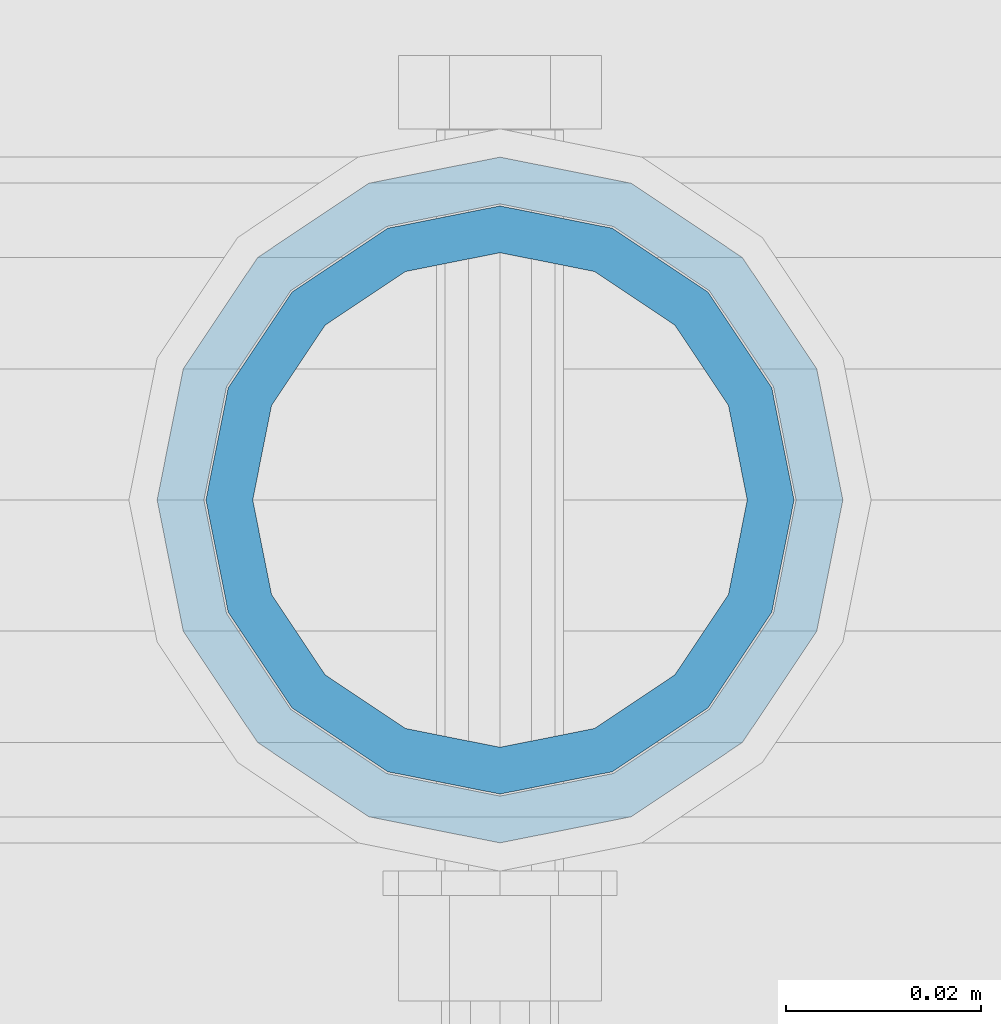
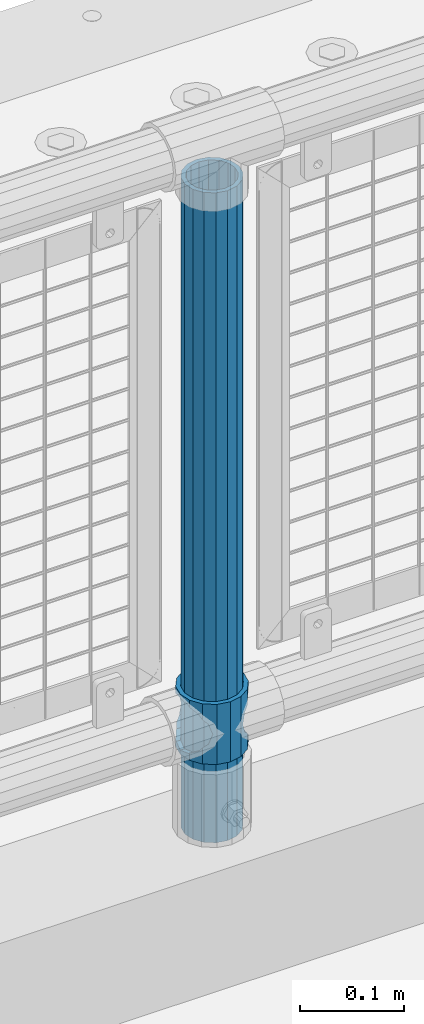
# One storey, part 64 of 242: 2 columns.
"""IFC2X3 building model written with IfcOpenShell, lengths in millimetres."""

from ifc_helpers import new_model, si_unit, frame, origin_with_axes, place, context, subcontext, project, spatial, faceted_brep, material, type_object, element, save


model = new_model("IFC2X3")

# Units and contexts
model_context = context("Model", 3, precision=1e-05, world=origin_with_axes())
body_context = subcontext(model_context, "Body", "Model", "MODEL_VIEW")
ifc_project = project(units=[si_unit("LENGTHUNIT", "METRE", prefix="MILLI"), si_unit("AREAUNIT", "SQUARE_METRE"), si_unit("VOLUMEUNIT", "CUBIC_METRE"), si_unit("MASSUNIT", "GRAM", prefix="KILO"), si_unit("TIMEUNIT", "SECOND"), si_unit("PLANEANGLEUNIT", "RADIAN"), si_unit("SOLIDANGLEUNIT", "STERADIAN"), si_unit("THERMODYNAMICTEMPERATUREUNIT", "DEGREE_CELSIUS"), si_unit("LUMINOUSINTENSITYUNIT", "LUMEN")], contexts=[model_context])

# Site, building, storey
site_placement = place(None, origin_with_axes())
site = spatial("IfcSite", under=ifc_project, at=site_placement, CompositionType="ELEMENT")
building_placement = place(site_placement, origin_with_axes())
building = spatial("IfcBuilding", under=site, at=building_placement, Name="Standard", CompositionType="ELEMENT")
storey_placement = place(building_placement, origin_with_axes())
storey = spatial("IfcBuildingStorey", under=building, at=storey_placement, Name="Undefined", CompositionType="ELEMENT", Elevation=0.0)

# Columns
ifc_material_1 = material()
column_type_1 = type_object("IfcColumnType", PredefinedType="NOTDEFINED")
column_1_placement = place(storey_placement, frame((-40196.0, -19335.5, 168.02), z_axis=(-1.0, 0.0, 0.0), x_axis=(0.0, 0.0, 1.0)))
element("IfcColumn", 1, at=column_1_placement, inside=storey, type_object=column_type_1, material=ifc_material_1, context=body_context, shape_type="Brep", body=[
    faceted_brep([(0.0, -25.3499999999985, 0.0), (0.0, -23.4203461491597, 9.70102501045403), (760.0, -23.4203461491597, 9.70102501045403), (760.0, -25.3499999999985, 0.0), (0.0, -17.9251569030785, 17.9251569030785), (760.0, -17.9251569030785, 17.9251569030785), (0.0, -9.70102501045403, 23.4203461491597), (760.0, -9.70102501045403, 23.4203461491597), (0.0, 0.0, 25.3499999999985), (760.0, 0.0, 25.3499999999985), (0.0, 9.70102501045403, 23.4203461491597), (760.0, 9.70102501045403, 23.4203461491597), (0.0, 17.9251569030785, 17.9251569030785), (760.0, 17.9251569030785, 17.9251569030785), (0.0, 23.4203461491597, 9.70102501045403), (760.0, 23.4203461491597, 9.70102501045403), (0.0, 25.3499999999985, 0.0), (760.0, 25.3499999999985, 0.0), (0.0, 23.4203461491597, -9.70102501045403), (760.0, 23.4203461491597, -9.70102501045403), (0.0, 17.9251569030785, -17.9251569030785), (760.0, 17.9251569030785, -17.9251569030785), (0.0, 9.70102501045403, -23.4203461491597), (760.0, 9.70102501045403, -23.4203461491597), (0.0, 0.0, -25.3499999999985), (760.0, 0.0, -25.3499999999985), (0.0, -9.70102501045403, -23.4203461491597), (760.0, -9.70102501045403, -23.4203461491597), (0.0, -17.9251569030785, -17.9251569030785), (760.0, -17.9251569030785, -17.9251569030785), (0.0, -23.4203461491597, -9.70102501045403), (760.0, -23.4203461491597, -9.70102501045403), (0.0, -30.1500000000015, 0.0), (0.0, -27.8549679052157, -11.5379054858058), (760.0, -27.8549679052157, -11.5379054858058), (760.0, -30.1500000000015, 0.0), (0.0, -21.3192694527752, -21.3192694527752), (760.0, -21.3192694527752, -21.3192694527752), (0.0, -11.5379054858058, -27.8549679052157), (760.0, -11.5379054858058, -27.8549679052157), (0.0, 0.0, -30.1500000000015), (760.0, 0.0, -30.1500000000015), (0.0, 11.5379054858058, -27.8549679052157), (760.0, 11.5379054858058, -27.8549679052157), (0.0, 21.3192694527752, -21.3192694527752), (760.0, 21.3192694527752, -21.3192694527752), (0.0, 27.8549679052157, -11.5379054858058), (760.0, 27.8549679052157, -11.5379054858058), (0.0, 30.1500000000015, 0.0), (760.0, 30.1500000000015, 0.0), (0.0, 27.8549679052157, 11.5379054858058), (760.0, 27.8549679052157, 11.5379054858058), (0.0, 21.3192694527752, 21.3192694527752), (760.0, 21.3192694527752, 21.3192694527752), (0.0, 11.5379054858058, 27.8549679052157), (760.0, 11.5379054858058, 27.8549679052157), (0.0, 0.0, 30.1500000000015), (760.0, 0.0, 30.1500000000015), (0.0, -11.5379054858058, 27.8549679052157), (760.0, -11.5379054858058, 27.8549679052157), (0.0, -21.3192694527752, 21.3192694527752), (760.0, -21.3192694527752, 21.3192694527752), (0.0, -27.8549679052157, 11.5379054858058), (760.0, -27.8549679052157, 11.5379054858058)], [[[0, 1, 2, 3]], [[1, 4, 5, 2]], [[4, 6, 7, 5]], [[6, 8, 9, 7]], [[8, 10, 11, 9]], [[10, 12, 13, 11]], [[12, 14, 15, 13]], [[14, 16, 17, 15]], [[16, 18, 19, 17]], [[18, 20, 21, 19]], [[20, 22, 23, 21]], [[22, 24, 25, 23]], [[24, 26, 27, 25]], [[26, 28, 29, 27]], [[28, 30, 31, 29]], [[30, 0, 3, 31]], [[32, 33, 34, 35]], [[33, 36, 37, 34]], [[36, 38, 39, 37]], [[38, 40, 41, 39]], [[40, 42, 43, 41]], [[42, 44, 45, 43]], [[44, 46, 47, 45]], [[46, 48, 49, 47]], [[48, 50, 51, 49]], [[50, 52, 53, 51]], [[52, 54, 55, 53]], [[54, 56, 57, 55]], [[56, 58, 59, 57]], [[58, 60, 61, 59]], [[60, 62, 63, 61]], [[62, 32, 35, 63]], [[37, 39, 41, 43, 45, 47, 49, 51, 53, 55, 57, 59, 61, 63, 35, 34], [5, 7, 9, 11, 13, 15, 17, 19, 21, 23, 25, 27, 29, 31, 3, 2]], [[62, 60, 58, 56, 54, 52, 50, 48, 46, 44, 42, 40, 38, 36, 33, 32], [30, 28, 26, 24, 22, 20, 18, 16, 14, 12, 10, 8, 6, 4, 1, 0]]]),
])
ifc_material_2 = material(Name="Misc_Undefined")
column_type_2 = type_object("IfcColumnType", PredefinedType="NOTDEFINED")
column_2_placement = place(storey_placement, frame((-40196.0, -19335.5, 263.02), z_axis=(-1.0, 0.0, 0.0), x_axis=(0.0, 0.0, 1.0)))
element("IfcColumn", 2, at=column_2_placement, inside=storey, type_object=column_type_2, material=ifc_material_2, context=body_context, shape_type="Brep", body=[
    faceted_brep([(63.1897438117172, 11.614442172282, -32.8397438117245), (63.1897438117172, 11.614442172282, -28.0397438117143), (56.6106908090114, 21.46069080901, -21.4606908090136), (56.6106908090114, 21.46069080901, -27.1226768591077), (61.9623795176744, 13.4513226476338, -32.4743655677739), (46.7644421722801, 28.0397438117179, -11.6144421722784), (46.7644421722801, 28.0397438117179, -20.0882031229849), (51.5310424080006, 24.8548033587067, -24.8548033587067), (35.1500000000015, 30.35, 0.0), (35.1499999999996, 30.3499999999985, -16.6306603983685), (23.5355578277192, 28.0397438117179, -11.6144421722784), (23.5355578277192, 28.0397438117179, -20.0882031229849), (18.7689575919987, 24.8548033587067, -24.8548033587067), (13.6893091909879, 21.46069080901, -21.4606908090136), (13.6893091909879, 21.46069080901, -27.1226768591077), (8.33762048232262, 13.4513226476338, -32.4743655677739), (7.11025618828211, 11.614442172282, -28.0397438117143), (7.11025618828211, 11.614442172282, -32.8397438117245), (4.79999999999961, 0.0, -30.3499999999985), (4.79999999999961, 0.0, -35.1500000000015), (7.11025618828211, -11.614442172282, -28.0397438117143), (7.11025618828211, -11.614442172282, -32.8397438117172), (13.6893091909879, -21.46069080901, -21.4606908090136), (13.6893091909879, -21.46069080901, -27.1226768591077), (8.33762048232484, -13.4513226476338, -32.4743655677739), (23.5355578277191, -28.0397438117179, -11.6144421722784), (23.5355578277191, -28.0397438117179, -20.0882031229921), (18.7689575919975, -24.8548033587067, -24.8548033587067), (35.1500000000015, -30.35, 0.0), (35.1499999999996, -30.3499999999985, -16.6306603983758), (46.7644421722801, -28.0397438117179, -11.6144421722784), (46.7644421722801, -28.0397438117179, -20.0882031229921), (51.5310424079973, -24.8548033587067, -24.8548033587067), (56.6106908090114, -21.46069080901, -21.4606908090136), (56.6106908090114, -21.46069080901, -27.1226768591077), (61.9623795176767, -13.4513226476338, -32.4743655677739), (63.1897438117172, -11.614442172282, -28.0397438117143), (63.1897438117172, -11.614442172282, -32.8397438117172), (65.4999999999997, 0.0, -30.3499999999985), (65.4999999999997, 0.0, -35.1500000000015), (0.0, -28.0397438117179, -11.6144421722784), (0.0, -30.3499999999985, 0.0), (0.0, -21.46069080901, -21.4606908090136), (0.0, -11.614442172282, -28.0397438117143), (0.0, 0.0, -30.3499999999985), (0.0, 11.614442172282, -28.0397438117143), (0.0, 21.46069080901, -21.4606908090136), (0.0, 28.0397438117179, -11.6144421722784), (0.0, 30.3499999999985, 0.0), (0.0, 28.0397438117179, 11.6144421722784), (23.5355578277192, 28.0397438117179, 11.614442172282), (0.0, 21.46069080901, 21.4606908090136), (13.6893091909879, 21.46069080901, 21.46069080901), (0.0, 11.614442172282, 28.0397438117143), (7.11025618828211, 11.614442172282, 28.0397438117179), (0.0, 0.0, 30.3499999999985), (4.79999999999961, 0.0, 30.3499999999985), (0.0, -11.614442172282, 28.0397438117143), (7.11025618828205, -11.614442172282, 28.0397438117179), (0.0, -21.46069080901, 21.4606908090136), (13.6893091909879, -21.46069080901, 21.46069080901), (0.0, -28.0397438117179, 11.6144421722784), (23.5355578277191, -28.0397438117179, 11.614442172282), (0.0, -32.4743655677703, 13.4513226476338), (0.0, -35.1500000000015, 0.0), (70.2999999999993, -35.1500000000015, 0.0), (70.2999999999993, -32.4743655677703, 13.4513226476338), (0.0, 13.4513226476338, -32.4743655677739), (0.0, 24.8548033587067, -24.8548033587067), (0.0, 0.0, -35.1500000000015), (0.0, -13.4513226476338, -32.4743655677739), (0.0, -24.8548033587067, -24.8548033587067), (0.0, -24.8548033587067, 24.8548033587067), (0.0, -13.4513226476338, 32.4743655677739), (0.0, 0.0, 35.1500000000015), (0.0, 13.4513226476338, 32.4743655677739), (0.0, 24.8548033587067, 24.8548033587067), (0.0, 32.4743655677703, 13.4513226476338), (0.0, 35.1500000000015, 0.0), (0.0, 32.4743655677703, -13.4513226476338), (0.0, -32.4743655677703, -13.4513226476338), (70.2999999999993, 32.4743655677703, 13.4513226476338), (70.2999999999993, 35.1500000000015, 0.0), (70.2999999999993, 32.4743655677703, -13.4513226476338), (70.2999999999993, 24.8548033587067, -24.8548033587067), (70.2999999999993, 13.4513226476338, -32.4743655677739), (70.2999999999993, 0.0, -35.1500000000015), (70.2999999999993, -13.4513226476338, -32.4743655677739), (70.2999999999993, -24.8548033587067, -24.8548033587067), (70.2999999999993, -32.4743655677703, -13.4513226476338), (70.2999999999993, 28.0397438117179, 11.6144421722784), (70.2999999999993, 21.46069080901, 21.4606908090136), (56.6106908090114, 21.46069080901, 21.46069080901), (46.7644421722801, 28.0397438117179, 11.614442172282), (70.2999999999993, 11.614442172282, 28.0397438117143), (63.1897438117172, 11.614442172282, 28.0397438117179), (70.2999999999993, 0.0, 30.3499999999985), (65.4999999999997, 0.0, 30.3499999999985), (70.2999999999993, -11.614442172282, 28.0397438117143), (63.1897438117172, -11.614442172282, 28.0397438117179), (70.2999999999993, -21.46069080901, 21.4606908090136), (56.6106908090114, -21.46069080901, 21.46069080901), (70.2999999999993, -28.0397438117179, 11.6144421722784), (46.7644421722801, -28.0397438117179, 11.614442172282), (70.2999999999993, -11.614442172282, -28.0397438117143), (70.2999999999993, 0.0, -30.3499999999985), (70.2999999999993, -21.46069080901, -21.4606908090136), (70.2999999999993, -28.0397438117179, -11.6144421722784), (70.2999999999993, -30.3499999999985, 0.0), (70.2999999999993, 24.8548033587067, 24.8548033587067), (70.2999999999993, 13.4513226476338, 32.4743655677739), (70.2999999999993, 0.0, 35.1500000000015), (70.2999999999993, -13.4513226476338, 32.4743655677739), (70.2999999999993, -24.8548033587067, 24.8548033587067), (70.2999999999993, 30.3499999999985, 0.0), (70.2999999999993, 28.0397438117179, -11.6144421722784), (70.2999999999993, 21.46069080901, -21.4606908090136), (70.2999999999993, 11.614442172282, -28.0397438117143), (61.9623795176744, 13.4513226476338, 32.4743655677703), (51.5310424080006, 24.8548033587067, 24.8548033587067), (56.6106908090114, 21.46069080901, 27.1226768591077), (65.4999999999997, 0.0, 35.1500000000015), (63.1897438117172, 11.614442172282, 32.8397438117136), (63.1897438117172, -11.614442172282, 32.8397438117172), (61.9623795176767, -13.4513226476338, 32.4743655677703), (56.6106908090114, -21.46069080901, 27.1226768591077), (51.5310424080038, -24.8548033587067, 24.8548033587067), (18.7689575919954, -24.8548033587067, 24.8548033587067), (46.7644421722801, -28.0397438117179, 20.0882031229885), (35.1499999999996, -30.3499999999985, 16.6306603983685), (23.5355578277191, -28.0397438117179, 20.0882031229885), (8.33762048232484, -13.4513226476338, 32.4743655677703), (13.6893091909879, -21.46069080901, 27.1226768591077), (4.79999999999961, 0.0, 35.1500000000015), (7.11025618828205, -11.614442172282, 32.8397438117172), (7.11025618828211, 11.614442172282, 32.8397438117136), (8.33762048232262, 13.4513226476338, 32.4743655677703), (13.6893091909879, 21.46069080901, 27.1226768591077), (18.768957592002, 24.8548033587067, 24.8548033587067), (23.5355578277192, 28.0397438117179, 20.0882031229812), (35.1499999999996, 30.3499999999985, 16.6306603983721), (46.7644421722801, 28.0397438117179, 20.0882031229812)], [[[0, 1, 2, 3, 4]], [[3, 2, 5, 6, 7]], [[6, 5, 8, 9]], [[9, 8, 10, 11]], [[12, 11, 10, 13, 14]], [[15, 14, 13, 16, 17]], [[17, 16, 18, 19]], [[19, 18, 20, 21]], [[21, 20, 22, 23, 24]], [[23, 22, 25, 26, 27]], [[26, 25, 28, 29]], [[29, 28, 30, 31]], [[32, 31, 30, 33, 34]], [[35, 34, 33, 36, 37]], [[37, 36, 38, 39]], [[39, 38, 1, 0]], [[40, 41, 28, 25]], [[42, 40, 25, 22]], [[43, 42, 22, 20]], [[44, 43, 20, 18]], [[45, 44, 18, 16]], [[46, 45, 16, 13]], [[47, 46, 13, 10]], [[48, 47, 10, 8]], [[49, 48, 8, 50]], [[51, 49, 50, 52]], [[53, 51, 52, 54]], [[55, 53, 54, 56]], [[57, 55, 56, 58]], [[59, 57, 58, 60]], [[61, 59, 60, 62]], [[41, 61, 62, 28]], [[63, 64, 65, 66]], [[67, 68, 12, 14, 15]], [[69, 67, 15, 17, 19]], [[24, 70, 69, 19, 21]], [[27, 71, 70, 24, 23]], [[63, 72, 73, 74, 75, 76, 77, 78, 79, 68, 67, 69, 70, 71, 80, 64], [40, 42, 43, 44, 45, 46, 47, 48, 49, 51, 53, 55, 57, 59, 61, 41]], [[78, 77, 81, 82]], [[79, 78, 82, 83]], [[68, 79, 83, 84, 7, 6, 9, 11, 12]], [[7, 84, 85, 4, 3]], [[4, 85, 86, 39, 0]], [[87, 88, 32, 34, 35]], [[86, 87, 35, 37, 39]], [[29, 31, 32, 88, 89, 80, 71, 27, 26]], [[64, 80, 89, 65]], [[90, 91, 92, 93]], [[91, 94, 95, 92]], [[94, 96, 97, 95]], [[96, 98, 99, 97]], [[98, 100, 101, 99]], [[100, 102, 103, 101]], [[104, 105, 38, 36]], [[106, 104, 36, 33]], [[107, 106, 33, 30]], [[108, 107, 30, 28]], [[102, 108, 28, 103]], [[88, 87, 86, 85, 84, 83, 82, 81, 109, 110, 111, 112, 113, 66, 65, 89], [100, 98, 96, 94, 91, 90, 114, 115, 116, 117, 105, 104, 106, 107, 108, 102]], [[118, 110, 109, 119, 120]], [[121, 111, 110, 118, 122]], [[112, 111, 121, 123, 124]], [[113, 112, 124, 125, 126]], [[127, 72, 63, 66, 113, 126, 128, 129, 130]], [[131, 73, 72, 127, 132]], [[133, 74, 73, 131, 134]], [[75, 74, 133, 135, 136]], [[76, 75, 136, 137, 138]], [[119, 109, 81, 77, 76, 138, 139, 140, 141]], [[92, 120, 119, 141, 93]], [[95, 122, 118, 120, 92]], [[97, 121, 122, 95]], [[99, 123, 121, 97]], [[101, 125, 124, 123, 99]], [[103, 128, 126, 125, 101]], [[28, 129, 128, 103]], [[62, 130, 129, 28]], [[60, 132, 127, 130, 62]], [[58, 134, 131, 132, 60]], [[56, 133, 134, 58]], [[54, 135, 133, 56]], [[52, 137, 136, 135, 54]], [[50, 139, 138, 137, 52]], [[8, 140, 139, 50]], [[93, 141, 140, 8]], [[114, 90, 93, 8]], [[115, 114, 8, 5]], [[116, 115, 5, 2]], [[117, 116, 2, 1]], [[105, 117, 1, 38]]]),
])

save(model, "model.ifc")
